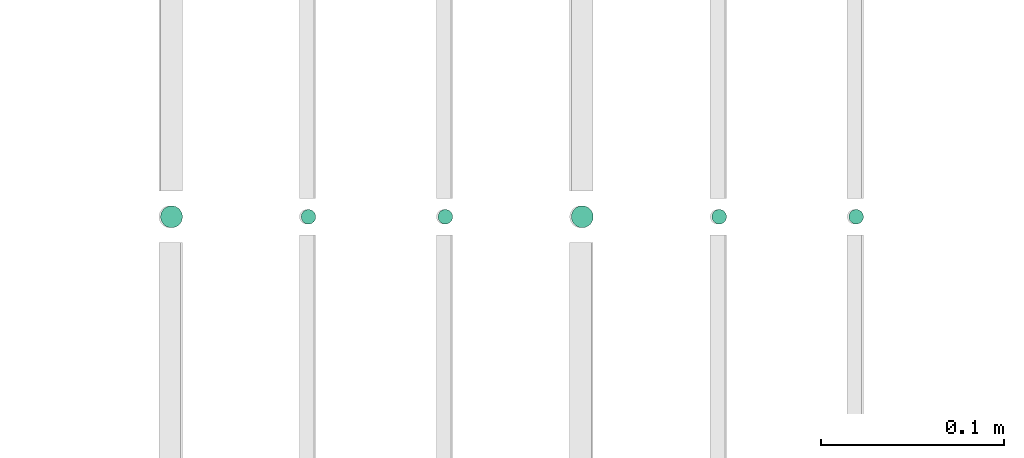
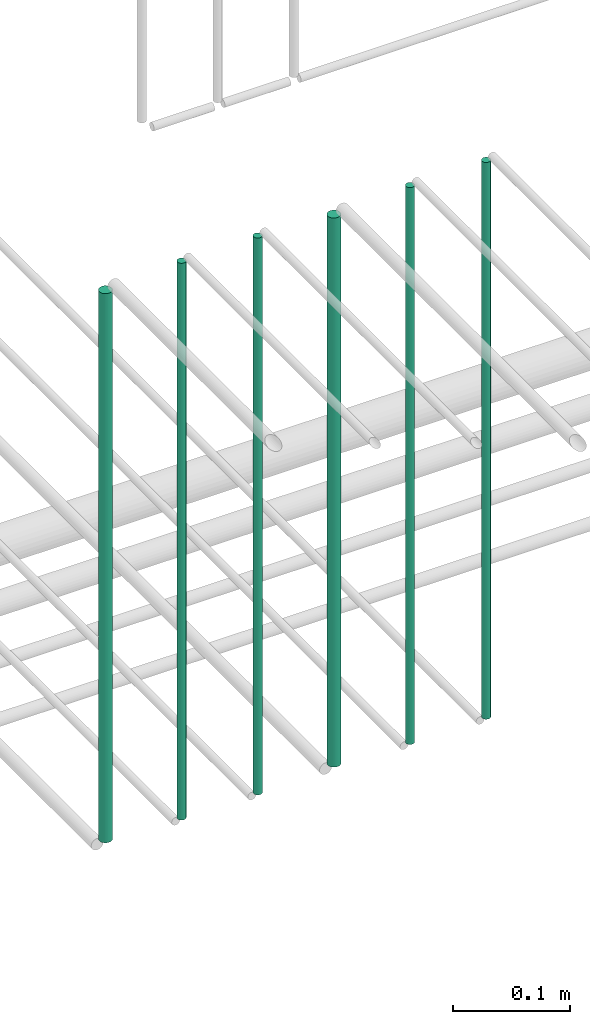
# One storey, part 196 of 331: 6 flow segments.
"""IFC2X3 building model written with IfcOpenShell, lengths in millimetres."""

from ifc_helpers import new_model, entity, si_unit, converted_unit, derived_unit, direction, frame, frame_2d, origin, origin_2d_with_axis, place, context, subcontext, project, spatial, circle, extrude, type_object, element, save


model = new_model("IFC2X3")

# Units and contexts
model_context = context("Model", 3, precision=0.01, world=origin(), true_north=direction((6.12303176911189e-17, 1.0)))
body_context = subcontext(model_context, "Body", "Model", "MODEL_VIEW")
ifc_project = project(units=[si_unit("LENGTHUNIT", "METRE", prefix="MILLI"), si_unit("AREAUNIT", "SQUARE_METRE"), si_unit("VOLUMEUNIT", "CUBIC_METRE"), converted_unit("PLANEANGLEUNIT", "DEGREE", entity("IfcRatioMeasure", 0.0174532925199433), si_unit("PLANEANGLEUNIT", "RADIAN"), dimensions=[0, 0, 0, 0, 0, 0, 0]), si_unit("MASSUNIT", "GRAM", prefix="KILO"), derived_unit("MASSDENSITYUNIT", [(si_unit("MASSUNIT", "GRAM", prefix="KILO"), 1), (si_unit("LENGTHUNIT", "METRE"), -3)]), derived_unit("MOMENTOFINERTIAUNIT", [(si_unit("LENGTHUNIT", "METRE"), 4)]), si_unit("TIMEUNIT", "SECOND"), si_unit("FREQUENCYUNIT", "HERTZ"), si_unit("THERMODYNAMICTEMPERATUREUNIT", "DEGREE_CELSIUS"), derived_unit("THERMALTRANSMITTANCEUNIT", [(si_unit("MASSUNIT", "GRAM", prefix="KILO"), 1), (si_unit("THERMODYNAMICTEMPERATUREUNIT", "KELVIN"), -1), (si_unit("TIMEUNIT", "SECOND"), -3)]), derived_unit("VOLUMETRICFLOWRATEUNIT", [(si_unit("LENGTHUNIT", "METRE"), 3), (si_unit("TIMEUNIT", "SECOND"), -1)]), derived_unit("MASSFLOWRATEUNIT", [(si_unit("MASSUNIT", "GRAM", prefix="KILO"), 1), (si_unit("TIMEUNIT", "SECOND"), -1)]), derived_unit("ROTATIONALFREQUENCYUNIT", [(si_unit("TIMEUNIT", "SECOND"), -1)]), si_unit("ELECTRICCURRENTUNIT", "AMPERE"), si_unit("ELECTRICVOLTAGEUNIT", "VOLT"), si_unit("POWERUNIT", "WATT"), si_unit("FORCEUNIT", "NEWTON", prefix="KILO"), si_unit("ILLUMINANCEUNIT", "LUX"), si_unit("LUMINOUSFLUXUNIT", "LUMEN"), si_unit("LUMINOUSINTENSITYUNIT", "CANDELA"), derived_unit("USERDEFINED", [(si_unit("MASSUNIT", "GRAM", prefix="KILO"), -1), (si_unit("LENGTHUNIT", "METRE"), -2), (si_unit("TIMEUNIT", "SECOND"), 3), (si_unit("LUMINOUSFLUXUNIT", "LUMEN"), 1)]), derived_unit("LINEARVELOCITYUNIT", [(si_unit("LENGTHUNIT", "METRE"), 1), (si_unit("TIMEUNIT", "SECOND"), -1)]), si_unit("PRESSUREUNIT", "PASCAL"), derived_unit("USERDEFINED", [(si_unit("LENGTHUNIT", "METRE"), -2), (si_unit("MASSUNIT", "GRAM", prefix="KILO"), 1), (si_unit("TIMEUNIT", "SECOND"), -2)]), derived_unit("LINEARFORCEUNIT", [(si_unit("MASSUNIT", "GRAM", prefix="KILO"), 1), (si_unit("LENGTHUNIT", "METRE"), 1), (si_unit("TIMEUNIT", "SECOND"), -2), (si_unit("LENGTHUNIT", "METRE"), -1)]), derived_unit("PLANARFORCEUNIT", [(si_unit("MASSUNIT", "GRAM", prefix="KILO"), 1), (si_unit("LENGTHUNIT", "METRE"), 1), (si_unit("TIMEUNIT", "SECOND"), -2), (si_unit("LENGTHUNIT", "METRE"), -2)])], contexts=[model_context])

# Site, building, storey
site_placement = place(None, frame((0.0, -0.00077364408347762, 0.0)))
site = spatial("IfcSite", under=ifc_project, at=site_placement, CompositionType="ELEMENT")
building_placement = place(site_placement, origin())
building = spatial("IfcBuilding", under=site, at=building_placement, CompositionType="ELEMENT")
storey_placement = place(building_placement, origin())
storey = spatial("IfcBuildingStorey", under=building, at=storey_placement, CompositionType="ELEMENT", Elevation=0.0)

# Flow segments
pipe_segment_type = type_object("IfcPipeSegmentType", PredefinedType="NOTDEFINED")
flow_segment_1_placement = place(storey_placement, frame((54065.5223318378, 5638.02529159143, 14560.0)))
element("IfcFlowSegment", 1, at=flow_segment_1_placement, inside=storey, type_object=pipe_segment_type, context=body_context, shape_type="SweptSolid", body=[
    extrude(circle(Radius=4.0, at=origin_2d_with_axis()), frame((5.59527223591499, 5.59527223591607, 0.0), z_axis=(0.0, 0.0, 1.0), x_axis=(-1.0, 0.0, 0.0)), (0.0, 0.0, 1.0), 580.000000000028),
])
flow_segment_2_placement = place(storey_placement, frame((53990.5223318378, 5638.02529159143, 14560.0)))
element("IfcFlowSegment", 2, at=flow_segment_2_placement, inside=storey, type_object=pipe_segment_type, context=body_context, shape_type="SweptSolid", body=[
    extrude(circle(Radius=4.0, at=frame_2d((0.0, -1.08286712929839e-12), x_axis=(1.0, 0.0))), frame((5.59527223591499, 5.59527223591499, 0.0), z_axis=(0.0, 0.0, 1.0), x_axis=(-1.0, 0.0, 0.0)), (0.0, 0.0, 1.0), 580.000000000009),
])
flow_segment_3_placement = place(storey_placement, frame((53913.5223318378, 5636.02529159143, 14564.0)))
element("IfcFlowSegment", 3, at=flow_segment_3_placement, inside=storey, type_object=pipe_segment_type, context=body_context, shape_type="SweptSolid", body=[
    extrude(circle(Radius=6.0, at=origin_2d_with_axis()), frame((7.59527223591454, 7.59527223591562, 0.0), z_axis=(0.0, 0.0, 1.0), x_axis=(-1.0, 0.0, 0.0)), (0.0, 0.0, 1.0), 572.0),
])
flow_segment_4_placement = place(storey_placement, frame((53840.5223318378, 5638.02529159143, 14560.0)))
element("IfcFlowSegment", 4, at=flow_segment_4_placement, inside=storey, type_object=pipe_segment_type, context=body_context, shape_type="SweptSolid", body=[
    extrude(circle(Radius=4.0, at=origin_2d_with_axis()), frame((5.59527223591499, 5.59527223591607, 0.0), z_axis=(0.0, 0.0, 1.0), x_axis=(-1.0, 0.0, 0.0)), (0.0, 0.0, 1.0), 580.000000000028),
])
flow_segment_5_placement = place(storey_placement, frame((53765.5223318378, 5638.02529159143, 14560.0)))
element("IfcFlowSegment", 5, at=flow_segment_5_placement, inside=storey, type_object=pipe_segment_type, context=body_context, shape_type="SweptSolid", body=[
    extrude(circle(Radius=4.0, at=origin_2d_with_axis()), frame((5.59527223591499, 5.59527223591607, 0.0), z_axis=(0.0, 0.0, 1.0), x_axis=(-1.0, 0.0, 0.0)), (0.0, 0.0, 1.0), 580.0),
])
flow_segment_6_placement = place(storey_placement, frame((53688.5223318378, 5636.02529159143, 14564.0)))
element("IfcFlowSegment", 6, at=flow_segment_6_placement, inside=storey, type_object=pipe_segment_type, context=body_context, shape_type="SweptSolid", body=[
    extrude(circle(Radius=6.0, at=origin_2d_with_axis()), frame((7.59527223591454, 7.59527223591562, 0.0), z_axis=(0.0, 0.0, 1.0), x_axis=(-1.0, 0.0, 0.0)), (0.0, 0.0, 1.0), 572.000000000011),
])

save(model, "model.ifc")
